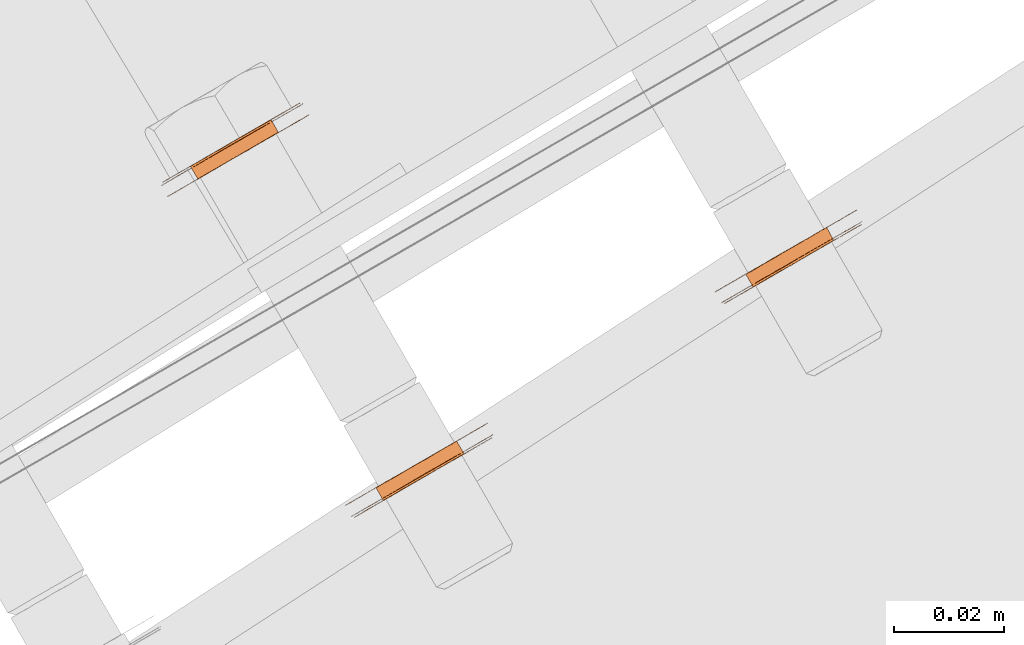
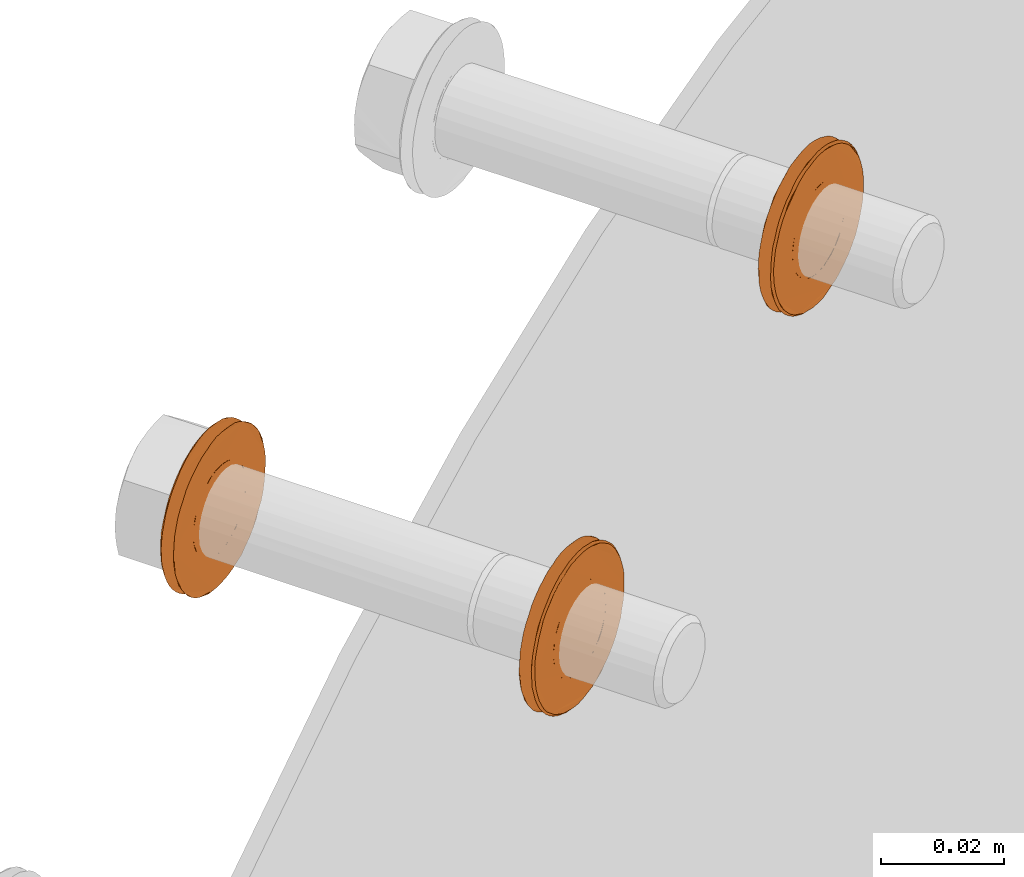
# One storey, part 108 of 126: 3 proxies.
"""IFC2X3 building model written with IfcOpenShell, lengths in millimetres."""

from ifc_helpers import new_model, si_unit, origin, origin_with_axes, place, context, project, spatial, faceted_brep, material, element, save


model = new_model("IFC2X3")

# Units and contexts
context_of_model_1 = context(None, 3, precision=0.1, world=origin())
context_of_model_2 = context(None, 3, precision=0.1, world=origin())
ifc_project = project(units=[si_unit("LENGTHUNIT", "METRE", prefix="MILLI"), si_unit("AREAUNIT", "SQUARE_METRE", prefix="CENTI"), si_unit("VOLUMEUNIT", "CUBIC_METRE", prefix="CENTI"), si_unit("MASSUNIT", "GRAM", prefix="KILO")], contexts=[context_of_model_1, context_of_model_2])

# Site, building, storey
site_placement = place(None, origin_with_axes())
site = spatial("IfcSite", under=ifc_project, at=site_placement, CompositionType="ELEMENT")
building_placement = place(site_placement, origin_with_axes())
building = spatial("IfcBuilding", under=site, at=building_placement, CompositionType="ELEMENT")
storey_placement = place(building_placement, origin_with_axes())
storey = spatial("IfcBuildingStorey", under=building, at=storey_placement, CompositionType="ELEMENT")

# Proxies
ifc_material = material(Name="STAHL")
proxy_1_placement = place(storey_placement, origin_with_axes())
element("IfcBuildingElementProxy", 1, at=proxy_1_placement, inside=storey, material=ifc_material, Name="profile", context=context_of_model_2, shape_type="Brep", body=[
    faceted_brep([(3844.0, 14806.0, 1266.7), (3842.7, 14808.3, 1266.7), (3841.6, 14807.7, 1266.9), (3843.0, 14805.4, 1266.9), (3845.1, 14806.6, 1266.8), (3843.7, 14808.9, 1266.8), (3846.1, 14807.2, 1267.0), (3844.8, 14809.5, 1267.0), (3840.5, 14804.0, 1282.5), (3839.2, 14806.3, 1282.5), (3840.1, 14806.8, 1283.1), (3841.5, 14804.5, 1283.1), (3847.1, 14807.8, 1267.4), (3845.8, 14810.1, 1267.4), (3839.7, 14803.5, 1281.8), (3838.3, 14805.8, 1281.8), (3838.9, 14803.0, 1281.0), (3837.6, 14805.4, 1281.0), (3838.3, 14802.6, 1280.1), (3836.9, 14805.0, 1280.1), (3837.7, 14802.3, 1279.0), (3836.4, 14804.7, 1279.0), (3837.3, 14802.1, 1277.9), (3836.0, 14804.4, 1277.9), (3837.1, 14801.9, 1276.7), (3835.7, 14804.3, 1276.7), (3836.9, 14801.9, 1275.5), (3835.6, 14804.2, 1275.5), (3837.0, 14801.9, 1274.3), (3835.6, 14804.2, 1274.3), (3837.2, 14802.0, 1273.1), (3835.8, 14804.4, 1273.1), (3837.5, 14802.2, 1272.0), (3836.2, 14804.5, 1272.0), (3838.0, 14802.5, 1270.9), (3836.6, 14804.8, 1270.9), (3838.6, 14802.8, 1269.9), (3837.2, 14805.2, 1269.9), (3839.3, 14803.2, 1269.0), (3837.9, 14805.6, 1269.0), (3840.1, 14803.7, 1268.2), (3838.8, 14806.0, 1268.2), (3841.0, 14804.2, 1267.6), (3839.7, 14806.6, 1267.6), (3842.0, 14804.8, 1267.2), (3840.6, 14807.1, 1267.2), (3831.1, 14799.0, 1275.6), (3831.2, 14799.0, 1277.2), (3831.5, 14799.2, 1278.7), (3831.9, 14799.4, 1280.2), (3832.4, 14799.7, 1281.7), (3833.0, 14800.1, 1283.1), (3833.8, 14800.5, 1284.4), (3834.7, 14801.0, 1285.6), (3835.7, 14801.6, 1286.6), (3836.7, 14802.2, 1287.6), (3837.9, 14802.9, 1288.4), (3839.1, 14803.6, 1289.1), (3840.4, 14804.3, 1289.6), (3841.7, 14805.1, 1290.0), (3843.1, 14805.9, 1290.2), (3844.4, 14806.7, 1290.2), (3845.8, 14807.5, 1290.1), (3847.1, 14808.2, 1289.8), (3848.4, 14809.0, 1289.4), (3849.7, 14809.7, 1288.8), (3850.9, 14810.4, 1288.0), (3852.0, 14811.0, 1287.1), (3853.0, 14811.6, 1286.1), (3854.0, 14812.2, 1285.0), (3854.8, 14812.7, 1283.7), (3855.5, 14813.1, 1282.4), (3856.1, 14813.4, 1281.0), (3856.6, 14813.7, 1279.5), (3856.9, 14813.9, 1278.0), (3857.1, 14814.0, 1276.4), (3857.1, 14814.0, 1274.8), (3857.0, 14813.9, 1273.3), (3856.7, 14813.8, 1271.7), (3856.4, 14813.5, 1270.2), (3855.8, 14813.2, 1268.8), (3855.2, 14812.9, 1267.4), (3854.4, 14812.4, 1266.1), (3853.5, 14811.9, 1264.9), (3852.5, 14811.3, 1263.8), (3851.5, 14810.7, 1262.9), (3850.3, 14810.1, 1262.0), (3849.1, 14809.3, 1261.4), (3847.8, 14808.6, 1260.8), (3846.5, 14807.8, 1260.5), (3845.1, 14807.1, 1260.3), (3843.8, 14806.3, 1260.2), (3842.4, 14805.5, 1260.4), (3841.1, 14804.7, 1260.6), (3839.8, 14804.0, 1261.1), (3838.5, 14803.2, 1261.7), (3837.3, 14802.6, 1262.4), (3836.2, 14801.9, 1263.3), (3835.0, 14803.9, 1263.3), (3836.2, 14804.6, 1262.4), (3837.4, 14805.2, 1261.7), (3838.6, 14806.0, 1261.1), (3839.9, 14806.7, 1260.6), (3841.3, 14807.5, 1260.4), (3842.6, 14808.3, 1260.2), (3844.0, 14809.1, 1260.3), (3845.3, 14809.8, 1260.5), (3846.6, 14810.6, 1260.8), (3847.9, 14811.3, 1261.4), (3849.2, 14812.0, 1262.0), (3850.3, 14812.7, 1262.9), (3851.4, 14813.3, 1263.8), (3852.4, 14813.9, 1264.9), (3853.3, 14814.4, 1266.1), (3854.0, 14814.9, 1267.4), (3854.7, 14815.2, 1268.8), (3855.2, 14815.5, 1270.2), (3855.6, 14815.8, 1271.7), (3855.8, 14815.9, 1273.3), (3855.9, 14816.0, 1274.8), (3855.9, 14815.9, 1276.4), (3855.7, 14815.8, 1278.0), (3855.4, 14815.7, 1279.5), (3855.0, 14815.4, 1281.0), (3854.4, 14815.1, 1282.4), (3853.7, 14814.7, 1283.7), (3852.8, 14814.2, 1285.0), (3851.9, 14813.6, 1286.1), (3850.9, 14813.0, 1287.1), (3849.7, 14812.4, 1288.0), (3848.5, 14811.7, 1288.8), (3847.3, 14811.0, 1289.4), (3846.0, 14810.2, 1289.8), (3844.7, 14809.4, 1290.1), (3843.3, 14808.7, 1290.2), (3841.9, 14807.9, 1290.2), (3840.6, 14807.1, 1290.0), (3839.3, 14806.3, 1289.6), (3838.0, 14805.6, 1289.1), (3836.8, 14804.9, 1288.4), (3835.6, 14804.2, 1287.6), (3834.5, 14803.6, 1286.6), (3833.5, 14803.0, 1285.6), (3832.7, 14802.5, 1284.4), (3831.9, 14802.1, 1283.1), (3831.2, 14801.7, 1281.7), (3830.7, 14801.4, 1280.2), (3830.3, 14801.2, 1278.7), (3830.1, 14801.0, 1277.2), (3830.0, 14801.0, 1275.6), (3830.0, 14801.0, 1274.0), (3830.2, 14801.1, 1272.5), (3830.5, 14801.3, 1271.0), (3831.0, 14801.5, 1269.5), (3831.5, 14801.9, 1268.1), (3832.3, 14802.3, 1266.7), (3833.1, 14802.8, 1265.5), (3834.0, 14803.3, 1264.3), (3835.2, 14801.3, 1264.3), (3834.2, 14800.8, 1265.5), (3833.4, 14800.3, 1266.7), (3832.7, 14799.9, 1268.1), (3832.1, 14799.5, 1269.5), (3831.7, 14799.3, 1271.0), (3831.3, 14799.1, 1272.5), (3831.2, 14799.0, 1274.0), (3831.7, 14798.8, 1275.0), (3831.7, 14798.9, 1276.6), (3831.9, 14799.0, 1278.2), (3832.3, 14799.2, 1279.7), (3832.8, 14799.5, 1281.2), (3833.4, 14799.8, 1282.6), (3834.1, 14800.3, 1283.9), (3835.0, 14800.8, 1285.1), (3836.0, 14801.3, 1286.2), (3837.1, 14802.0, 1287.2), (3838.2, 14802.6, 1288.0), (3839.5, 14803.3, 1288.7), (3840.8, 14804.1, 1289.2), (3842.1, 14804.9, 1289.6), (3843.5, 14805.6, 1289.8), (3844.8, 14806.4, 1289.8), (3846.2, 14807.2, 1289.7), (3847.5, 14808.0, 1289.3), (3848.8, 14808.7, 1288.9), (3850.1, 14809.5, 1288.2), (3851.3, 14810.1, 1287.4), (3852.4, 14810.8, 1286.5), (3853.4, 14811.4, 1285.4), (3854.3, 14811.9, 1284.2), (3855.1, 14812.3, 1282.9), (3855.7, 14812.7, 1281.5), (3856.2, 14813.0, 1280.1), (3856.6, 14813.2, 1278.6), (3856.9, 14813.4, 1277.0), (3856.9, 14813.4, 1275.4), (3856.9, 14813.4, 1273.8), (3856.7, 14813.3, 1272.3), (3856.3, 14813.1, 1270.8), (3855.9, 14812.8, 1269.3), (3855.2, 14812.4, 1267.9), (3854.5, 14812.0, 1266.5), (3853.6, 14811.5, 1265.3), (3852.6, 14810.9, 1264.2), (3851.5, 14810.3, 1263.3), (3850.4, 14809.6, 1262.4), (3849.1, 14808.9, 1261.7), (3847.9, 14808.2, 1261.2), (3846.5, 14807.4, 1260.9), (3845.2, 14806.6, 1260.7), (3843.8, 14805.8, 1260.6), (3842.4, 14805.0, 1260.8), (3841.1, 14804.3, 1261.1), (3839.8, 14803.5, 1261.6), (3838.5, 14802.8, 1262.2), (3837.4, 14802.1, 1263.0), (3836.3, 14801.5, 1264.0), (3835.2, 14800.9, 1265.0), (3834.3, 14800.4, 1266.2), (3833.6, 14799.9, 1267.5), (3832.9, 14799.5, 1268.9), (3832.4, 14799.2, 1270.4), (3832.0, 14799.0, 1271.9), (3831.8, 14798.9, 1273.5), (3850.9, 14809.9, 1271.4), (3850.4, 14809.6, 1270.4), (3849.7, 14809.2, 1269.4), (3848.9, 14808.8, 1268.6), (3848.1, 14808.3, 1267.9), (3842.5, 14805.1, 1283.5), (3843.5, 14805.7, 1283.7), (3844.6, 14806.3, 1283.7), (3845.6, 14806.9, 1283.6), (3846.6, 14807.5, 1283.3), (3847.6, 14808.0, 1282.8), (3848.5, 14808.6, 1282.2), (3849.3, 14809.0, 1281.4), (3850.0, 14809.4, 1280.6), (3850.6, 14809.8, 1279.6), (3851.1, 14810.1, 1278.5), (3851.4, 14810.2, 1277.3), (3851.6, 14810.4, 1276.1), (3851.7, 14810.4, 1274.9), (3851.6, 14810.3, 1273.7), (3851.3, 14810.2, 1272.5), (3843.2, 14808.6, 1283.7), (3844.3, 14809.2, 1283.6), (3842.2, 14808.0, 1283.7), (3841.1, 14807.4, 1283.5), (3846.7, 14810.6, 1267.9), (3847.6, 14811.1, 1268.6), (3848.3, 14811.6, 1269.4), (3849.0, 14812.0, 1270.4), (3849.5, 14812.3, 1271.4), (3849.9, 14812.5, 1272.5), (3850.2, 14812.7, 1273.7), (3850.3, 14812.7, 1274.9), (3850.3, 14812.7, 1276.1), (3850.1, 14812.6, 1277.3), (3849.8, 14812.4, 1278.5), (3849.3, 14812.1, 1279.6), (3848.7, 14811.8, 1280.6), (3848.0, 14811.4, 1281.4), (3847.2, 14810.9, 1282.2), (3846.3, 14810.4, 1282.8), (3845.3, 14809.8, 1283.3)], [[[0, 1, 2, 3]], [[4, 5, 1, 0]], [[6, 7, 5, 4]], [[8, 9, 10, 11]], [[12, 13, 7, 6]], [[14, 15, 9, 8]], [[16, 17, 15, 14]], [[18, 19, 17, 16]], [[20, 21, 19, 18]], [[22, 23, 21, 20]], [[24, 25, 23, 22]], [[26, 27, 25, 24]], [[28, 29, 27, 26]], [[30, 31, 29, 28]], [[32, 33, 31, 30]], [[34, 35, 33, 32]], [[36, 37, 35, 34]], [[38, 39, 37, 36]], [[40, 41, 39, 38]], [[42, 43, 41, 40]], [[44, 45, 43, 42]], [[3, 2, 45, 44]], [[46, 47, 48, 49, 50, 51, 52, 53, 54, 55, 56, 57, 58, 59, 60, 61, 62, 63, 64, 65, 66, 67, 68, 69, 70, 71, 72, 73, 74, 75, 76, 77, 78, 79, 80, 81, 82, 83, 84, 85, 86, 87, 88, 89, 90, 91, 92, 93, 94, 95, 96, 97, 98, 99, 100, 101, 102, 103, 104, 105, 106, 107, 108, 109, 110, 111, 112, 113, 114, 115, 116, 117, 118, 119, 120, 121, 122, 123, 124, 125, 126, 127, 128, 129, 130, 131, 132, 133, 134, 135, 136, 137, 138, 139, 140, 141, 142, 143, 144, 145, 146, 147, 148, 149, 150, 151, 152, 153, 154, 155, 156, 157, 98, 97, 158, 159, 160, 161, 162, 163, 164, 165]], [[166, 167, 168, 169, 170, 171, 172, 173, 174, 175, 176, 177, 178, 179, 180, 181, 182, 183, 184, 185, 186, 187, 188, 189, 190, 191, 192, 193, 194, 195, 196, 197, 198, 79, 78, 77, 76, 75, 74, 73, 72, 71, 70, 69, 68, 67, 66, 65, 64, 63, 62, 61, 60, 59, 58, 57, 56, 55, 54, 53, 52, 51, 50, 49, 48, 47, 46, 165, 164, 163, 162, 161, 160, 159, 158, 97, 96, 95, 94, 93, 92, 91, 90, 89, 88, 87, 86, 85, 84, 83, 82, 81, 80, 79, 198, 199, 200, 201, 202, 203, 204, 205, 206, 207, 208, 209, 210, 211, 212, 213, 214, 215, 216, 217, 218, 219, 220, 221, 222, 223]], [[166, 223, 222, 221, 220, 219, 218, 217, 216, 215, 214, 213, 212, 211, 210, 209, 208, 207, 206, 205, 204, 203, 202, 201, 200, 199, 224, 225, 226, 227, 228, 12, 6, 4, 0, 3, 44, 42, 40, 38, 36, 34, 32, 30, 28, 26, 24, 22, 20, 18, 16, 14, 8, 11, 229, 230, 231, 232, 233, 234, 235, 236, 237, 238, 239, 240, 241, 242, 243, 244, 224, 199, 198, 197, 196, 195, 194, 193, 192, 191, 190, 189, 188, 187, 186, 185, 184, 183, 182, 181, 180, 179, 178, 177, 176, 175, 174, 173, 172, 171, 170, 169, 168, 167]], [[231, 245, 246, 232]], [[230, 247, 245, 231]], [[229, 248, 247, 230]], [[228, 249, 13, 12]], [[11, 10, 248, 229]], [[227, 250, 249, 228]], [[226, 251, 250, 227]], [[225, 252, 251, 226]], [[224, 253, 252, 225]], [[244, 254, 253, 224]], [[243, 255, 254, 244]], [[242, 256, 255, 243]], [[241, 257, 256, 242]], [[240, 258, 257, 241]], [[239, 259, 258, 240]], [[238, 260, 259, 239]], [[237, 261, 260, 238]], [[236, 262, 261, 237]], [[235, 263, 262, 236]], [[234, 264, 263, 235]], [[233, 265, 264, 234]], [[232, 246, 265, 233]], [[149, 148, 147, 146, 145, 144, 143, 142, 141, 140, 139, 138, 137, 136, 135, 134, 133, 132, 131, 130, 129, 128, 127, 126, 125, 124, 123, 122, 121, 120, 119, 118, 117, 116, 254, 255, 256, 257, 258, 259, 260, 261, 262, 263, 264, 265, 246, 245, 247, 248, 10, 9, 15, 17, 19, 21, 23, 25, 27, 29, 31, 33, 35, 37, 39, 41, 43, 45, 2, 1, 5, 7, 13, 249, 250, 251, 252, 253, 254, 116, 115, 114, 113, 112, 111, 110, 109, 108, 107, 106, 105, 104, 103, 102, 101, 100, 99, 98, 157, 156, 155, 154, 153, 152, 151, 150]]]),
])
proxy_2_placement = place(storey_placement, origin_with_axes())
element("IfcBuildingElementProxy", 2, at=proxy_2_placement, inside=storey, material=ifc_material, Name="profile", context=context_of_model_2, shape_type="Brep", body=[
    faceted_brep([(3814.5, 14870.2, 1269.4), (3815.8, 14867.9, 1269.4), (3816.5, 14868.3, 1270.4), (3815.2, 14870.6, 1270.4), (3813.7, 14869.8, 1268.6), (3815.1, 14867.4, 1268.6), (3812.9, 14869.3, 1267.9), (3814.2, 14866.9, 1267.9), (3807.3, 14866.0, 1283.5), (3808.6, 14863.7, 1283.5), (3807.6, 14863.1, 1283.1), (3806.3, 14865.5, 1283.1), (3811.9, 14868.7, 1267.4), (3813.3, 14866.4, 1267.4), (3808.3, 14866.6, 1283.7), (3809.7, 14864.3, 1283.7), (3809.4, 14867.3, 1283.7), (3810.7, 14864.9, 1283.7), (3810.4, 14867.9, 1283.6), (3811.8, 14865.5, 1283.6), (3811.4, 14868.4, 1283.3), (3812.8, 14866.1, 1283.3), (3812.4, 14869.0, 1282.8), (3813.8, 14866.7, 1282.8), (3813.3, 14869.5, 1282.2), (3814.7, 14867.2, 1282.2), (3814.1, 14870.0, 1281.4), (3815.5, 14867.7, 1281.4), (3814.8, 14870.4, 1280.6), (3816.2, 14868.1, 1280.6), (3815.4, 14870.8, 1279.6), (3816.8, 14868.4, 1279.6), (3815.9, 14871.0, 1278.5), (3817.3, 14868.7, 1278.5), (3816.2, 14871.2, 1277.3), (3817.6, 14868.9, 1277.3), (3816.4, 14871.3, 1276.1), (3817.8, 14869.0, 1276.1), (3816.5, 14871.3, 1274.9), (3817.8, 14869.0, 1274.9), (3816.4, 14871.3, 1273.7), (3817.7, 14868.9, 1273.7), (3816.1, 14871.1, 1272.5), (3817.4, 14868.8, 1272.5), (3815.7, 14870.9, 1271.4), (3817.0, 14868.6, 1271.4), (3797.5, 14857.3, 1275.6), (3797.6, 14857.3, 1277.2), (3797.8, 14857.5, 1278.7), (3798.2, 14857.7, 1280.2), (3798.7, 14858.0, 1281.7), (3799.4, 14858.4, 1283.1), (3800.2, 14858.8, 1284.4), (3801.0, 14859.3, 1285.6), (3802.0, 14859.9, 1286.6), (3803.1, 14860.5, 1287.6), (3804.3, 14861.2, 1288.4), (3805.5, 14861.9, 1289.1), (3806.8, 14862.6, 1289.6), (3808.1, 14863.4, 1290.0), (3809.4, 14864.2, 1290.2), (3810.8, 14865.0, 1290.2), (3812.2, 14865.7, 1290.1), (3813.5, 14866.5, 1289.8), (3814.8, 14867.3, 1289.4), (3816.0, 14868.0, 1288.8), (3817.2, 14868.7, 1288.0), (3818.4, 14869.3, 1287.1), (3819.4, 14869.9, 1286.1), (3820.3, 14870.5, 1285.0), (3821.2, 14870.9, 1283.7), (3821.9, 14871.4, 1282.4), (3822.5, 14871.7, 1281.0), (3822.9, 14872.0, 1279.5), (3823.2, 14872.1, 1278.0), (3823.4, 14872.2, 1276.4), (3823.4, 14872.3, 1274.8), (3823.3, 14872.2, 1273.3), (3823.1, 14872.1, 1271.7), (3821.9, 14874.0, 1271.7), (3822.2, 14874.2, 1273.3), (3822.3, 14874.3, 1274.8), (3822.3, 14874.2, 1276.4), (3822.1, 14874.1, 1278.0), (3821.8, 14873.9, 1279.5), (3821.3, 14873.7, 1281.0), (3820.7, 14873.3, 1282.4), (3820.0, 14872.9, 1283.7), (3819.2, 14872.5, 1285.0), (3818.2, 14871.9, 1286.1), (3817.2, 14871.3, 1287.1), (3816.1, 14870.7, 1288.0), (3814.9, 14870.0, 1288.8), (3813.6, 14869.3, 1289.4), (3812.3, 14868.5, 1289.8), (3811.0, 14867.7, 1290.1), (3809.6, 14867.0, 1290.2), (3808.3, 14866.2, 1290.2), (3806.9, 14865.4, 1290.0), (3805.6, 14864.6, 1289.6), (3804.3, 14863.9, 1289.1), (3803.1, 14863.2, 1288.4), (3801.9, 14862.5, 1287.6), (3800.9, 14861.9, 1286.6), (3799.9, 14861.3, 1285.6), (3799.0, 14860.8, 1284.4), (3798.2, 14860.4, 1283.1), (3797.6, 14860.0, 1281.7), (3797.1, 14859.7, 1280.2), (3796.7, 14859.5, 1278.7), (3796.4, 14859.3, 1277.2), (3796.3, 14859.3, 1275.6), (3796.4, 14859.3, 1274.0), (3796.5, 14859.4, 1272.5), (3796.9, 14859.6, 1271.0), (3797.3, 14859.8, 1269.5), (3797.9, 14860.2, 1268.1), (3798.6, 14860.6, 1266.7), (3799.4, 14861.1, 1265.5), (3800.4, 14861.6, 1264.3), (3801.4, 14862.2, 1263.3), (3802.5, 14862.8, 1262.4), (3803.7, 14863.5, 1261.7), (3805.0, 14864.3, 1261.1), (3806.3, 14865.0, 1260.6), (3807.6, 14865.8, 1260.4), (3809.0, 14866.6, 1260.2), (3810.3, 14867.3, 1260.3), (3811.7, 14868.1, 1260.5), (3813.0, 14868.9, 1260.8), (3814.3, 14869.6, 1261.4), (3815.5, 14870.3, 1262.0), (3816.7, 14871.0, 1262.9), (3817.7, 14871.6, 1263.8), (3818.7, 14872.2, 1264.9), (3819.6, 14872.7, 1266.1), (3820.4, 14873.1, 1267.4), (3821.0, 14873.5, 1268.8), (3821.6, 14873.8, 1270.2), (3822.7, 14871.8, 1270.2), (3822.2, 14871.5, 1268.8), (3821.5, 14871.2, 1267.4), (3820.8, 14870.7, 1266.1), (3819.9, 14870.2, 1264.9), (3818.9, 14869.6, 1263.8), (3817.8, 14869.0, 1262.9), (3816.7, 14868.3, 1262.0), (3815.4, 14867.6, 1261.4), (3814.1, 14866.9, 1260.8), (3812.8, 14866.1, 1260.5), (3811.5, 14865.4, 1260.3), (3810.1, 14864.6, 1260.2), (3808.8, 14863.8, 1260.4), (3807.4, 14863.0, 1260.6), (3806.1, 14862.3, 1261.1), (3804.9, 14861.5, 1261.7), (3803.7, 14860.8, 1262.4), (3802.5, 14860.2, 1263.3), (3801.5, 14859.6, 1264.3), (3800.6, 14859.1, 1265.5), (3799.8, 14858.6, 1266.7), (3799.0, 14858.2, 1268.1), (3798.5, 14857.8, 1269.5), (3798.0, 14857.6, 1271.0), (3797.7, 14857.4, 1272.5), (3797.5, 14857.3, 1274.0), (3803.3, 14863.8, 1262.2), (3804.6, 14864.5, 1261.6), (3805.9, 14865.2, 1261.1), (3807.2, 14866.0, 1260.8), (3808.6, 14866.8, 1260.6), (3810.0, 14867.6, 1260.7), (3811.3, 14868.4, 1260.9), (3812.7, 14869.1, 1261.2), (3813.9, 14869.9, 1261.7), (3815.2, 14870.6, 1262.4), (3816.3, 14871.3, 1263.3), (3817.4, 14871.9, 1264.2), (3818.4, 14872.5, 1265.3), (3819.3, 14873.0, 1266.5), (3820.0, 14873.4, 1267.9), (3820.7, 14873.8, 1269.3), (3821.1, 14874.0, 1270.8), (3821.5, 14874.3, 1272.3), (3821.7, 14874.4, 1273.8), (3821.7, 14874.4, 1275.4), (3821.7, 14874.3, 1277.0), (3821.4, 14874.2, 1278.6), (3821.0, 14874.0, 1280.1), (3820.5, 14873.7, 1281.5), (3819.9, 14873.3, 1282.9), (3819.1, 14872.9, 1284.2), (3818.2, 14872.3, 1285.4), (3817.2, 14871.8, 1286.5), (3816.1, 14871.1, 1287.4), (3814.9, 14870.4, 1288.2), (3813.6, 14869.7, 1288.9), (3812.3, 14869.0, 1289.3), (3811.0, 14868.2, 1289.7), (3809.6, 14867.4, 1289.8), (3808.3, 14866.6, 1289.8), (3806.9, 14865.8, 1289.6), (3805.6, 14865.1, 1289.2), (3804.3, 14864.3, 1288.7), (3803.0, 14863.6, 1288.0), (3801.9, 14862.9, 1287.2), (3800.8, 14862.3, 1286.2), (3799.8, 14861.7, 1285.1), (3798.9, 14861.2, 1283.9), (3798.2, 14860.8, 1282.6), (3797.6, 14860.4, 1281.2), (3797.1, 14860.2, 1279.7), (3796.7, 14860.0, 1278.2), (3796.5, 14859.8, 1276.6), (3796.5, 14859.8, 1275.0), (3796.6, 14859.9, 1273.5), (3796.8, 14860.0, 1271.9), (3797.2, 14860.2, 1270.4), (3797.7, 14860.5, 1268.9), (3798.4, 14860.9, 1267.5), (3799.1, 14861.3, 1266.2), (3800.0, 14861.9, 1265.0), (3801.1, 14862.5, 1264.0), (3802.2, 14863.1, 1263.0), (3806.8, 14865.8, 1267.2), (3807.8, 14866.3, 1266.9), (3808.8, 14866.9, 1266.7), (3809.9, 14867.6, 1266.8), (3810.9, 14868.2, 1267.0), (3805.3, 14864.9, 1282.5), (3804.5, 14864.4, 1281.8), (3803.7, 14864.0, 1281.0), (3803.1, 14863.6, 1280.1), (3802.5, 14863.3, 1279.0), (3802.1, 14863.1, 1277.9), (3801.9, 14862.9, 1276.7), (3801.7, 14862.9, 1275.5), (3801.8, 14862.9, 1274.3), (3802.0, 14863.0, 1273.1), (3802.3, 14863.2, 1272.0), (3802.8, 14863.4, 1270.9), (3803.4, 14863.8, 1269.9), (3804.1, 14864.2, 1269.0), (3804.9, 14864.7, 1268.2), (3805.8, 14865.2, 1267.6), (3805.1, 14861.7, 1281.0), (3804.4, 14861.3, 1280.1), (3805.8, 14862.1, 1281.8), (3806.7, 14862.6, 1282.5), (3812.3, 14865.8, 1267.0), (3811.2, 14865.2, 1266.8), (3810.2, 14864.6, 1266.7), (3809.1, 14864.0, 1266.9), (3808.1, 14863.4, 1267.2), (3807.2, 14862.9, 1267.6), (3806.3, 14862.3, 1268.2), (3805.4, 14861.9, 1269.0), (3804.7, 14861.5, 1269.9), (3804.1, 14861.1, 1270.9), (3803.7, 14860.8, 1272.0), (3803.3, 14860.6, 1273.1), (3803.1, 14860.5, 1274.3), (3803.1, 14860.5, 1275.5), (3803.2, 14860.6, 1276.7), (3803.5, 14860.7, 1277.9), (3803.9, 14861.0, 1279.0)], [[[0, 1, 2, 3]], [[4, 5, 1, 0]], [[6, 7, 5, 4]], [[8, 9, 10, 11]], [[12, 13, 7, 6]], [[14, 15, 9, 8]], [[16, 17, 15, 14]], [[18, 19, 17, 16]], [[20, 21, 19, 18]], [[22, 23, 21, 20]], [[24, 25, 23, 22]], [[26, 27, 25, 24]], [[28, 29, 27, 26]], [[30, 31, 29, 28]], [[32, 33, 31, 30]], [[34, 35, 33, 32]], [[36, 37, 35, 34]], [[38, 39, 37, 36]], [[40, 41, 39, 38]], [[42, 43, 41, 40]], [[44, 45, 43, 42]], [[3, 2, 45, 44]], [[46, 47, 48, 49, 50, 51, 52, 53, 54, 55, 56, 57, 58, 59, 60, 61, 62, 63, 64, 65, 66, 67, 68, 69, 70, 71, 72, 73, 74, 75, 76, 77, 78, 79, 80, 81, 82, 83, 84, 85, 86, 87, 88, 89, 90, 91, 92, 93, 94, 95, 96, 97, 98, 99, 100, 101, 102, 103, 104, 105, 106, 107, 108, 109, 110, 111, 112, 113, 114, 115, 116, 117, 118, 119, 120, 121, 122, 123, 124, 125, 126, 127, 128, 129, 130, 131, 132, 133, 134, 135, 136, 137, 138, 79, 78, 139, 140, 141, 142, 143, 144, 145, 146, 147, 148, 149, 150, 151, 152, 153, 154, 155, 156, 157, 158, 159, 160, 161, 162, 163, 164, 165]], [[111, 110, 109, 108, 107, 106, 105, 104, 103, 102, 101, 100, 99, 98, 97, 96, 95, 94, 93, 92, 91, 90, 89, 88, 87, 86, 85, 84, 83, 82, 81, 80, 79, 138, 137, 136, 135, 134, 133, 132, 131, 130, 129, 128, 127, 126, 125, 124, 123, 122, 166, 167, 168, 169, 170, 171, 172, 173, 174, 175, 176, 177, 178, 179, 180, 181, 182, 183, 184, 185, 186, 187, 188, 189, 190, 191, 192, 193, 194, 195, 196, 197, 198, 199, 200, 201, 202, 203, 204, 205, 206, 207, 208, 209, 210, 211, 212, 213, 214, 215, 216, 217, 218, 219, 220, 221, 222, 223, 166, 122, 121, 120, 119, 118, 117, 116, 115, 114, 113, 112]], [[214, 213, 212, 211, 210, 209, 208, 207, 206, 205, 204, 203, 202, 201, 200, 199, 198, 197, 196, 195, 194, 193, 192, 191, 190, 189, 188, 187, 186, 185, 184, 183, 182, 181, 180, 179, 178, 177, 176, 175, 174, 173, 172, 171, 170, 169, 168, 167, 224, 225, 226, 227, 228, 12, 6, 4, 0, 3, 44, 42, 40, 38, 36, 34, 32, 30, 28, 26, 24, 22, 20, 18, 16, 14, 8, 11, 229, 230, 231, 232, 233, 234, 235, 236, 237, 238, 239, 240, 241, 242, 243, 244, 224, 167, 166, 223, 222, 221, 220, 219, 218, 217, 216, 215]], [[231, 245, 246, 232]], [[230, 247, 245, 231]], [[229, 248, 247, 230]], [[228, 249, 13, 12]], [[11, 10, 248, 229]], [[227, 250, 249, 228]], [[226, 251, 250, 227]], [[225, 252, 251, 226]], [[224, 253, 252, 225]], [[244, 254, 253, 224]], [[243, 255, 254, 244]], [[242, 256, 255, 243]], [[241, 257, 256, 242]], [[240, 258, 257, 241]], [[239, 259, 258, 240]], [[238, 260, 259, 239]], [[237, 261, 260, 238]], [[236, 262, 261, 237]], [[235, 263, 262, 236]], [[234, 264, 263, 235]], [[233, 265, 264, 234]], [[232, 246, 265, 233]], [[46, 165, 164, 163, 162, 161, 160, 159, 158, 157, 156, 155, 154, 254, 255, 256, 257, 258, 259, 260, 261, 262, 263, 264, 265, 246, 245, 247, 248, 10, 9, 15, 17, 19, 21, 23, 25, 27, 29, 31, 33, 35, 37, 39, 41, 43, 45, 2, 1, 5, 7, 13, 249, 250, 251, 252, 253, 254, 154, 153, 152, 151, 150, 149, 148, 147, 146, 145, 144, 143, 142, 141, 140, 139, 78, 77, 76, 75, 74, 73, 72, 71, 70, 69, 68, 67, 66, 65, 64, 63, 62, 61, 60, 59, 58, 57, 56, 55, 54, 53, 52, 51, 50, 49, 48, 47]]]),
])
proxy_3_placement = place(storey_placement, origin_with_axes())
element("IfcBuildingElementProxy", 3, at=proxy_3_placement, inside=storey, material=ifc_material, Name="profile", context=context_of_model_2, shape_type="Brep", body=[
    faceted_brep([(3911.1, 14844.7, 1299.0), (3909.7, 14847.0, 1299.0), (3908.7, 14846.4, 1299.2), (3910.1, 14844.1, 1299.2), (3912.1, 14845.3, 1299.0), (3910.8, 14847.6, 1299.0), (3910.3, 14844.2, 1315.8), (3909.3, 14843.7, 1315.5), (3908.0, 14846.0, 1315.5), (3909.0, 14846.6, 1315.8), (3913.2, 14845.9, 1299.1), (3911.8, 14848.2, 1299.1), (3908.3, 14843.1, 1315.0), (3907.0, 14845.4, 1315.0), (3907.4, 14842.6, 1314.4), (3906.1, 14844.9, 1314.4), (3906.6, 14842.1, 1313.6), (3905.3, 14844.5, 1313.6), (3905.9, 14841.7, 1312.7), (3904.6, 14844.1, 1312.7), (3905.4, 14841.4, 1311.7), (3904.0, 14843.7, 1311.7), (3904.9, 14841.1, 1310.6), (3903.6, 14843.5, 1310.6), (3904.6, 14840.9, 1309.4), (3903.2, 14843.3, 1309.4), (3904.4, 14840.8, 1308.2), (3903.1, 14843.2, 1308.2), (3904.4, 14840.8, 1307.0), (3903.0, 14843.2, 1307.0), (3904.5, 14840.9, 1305.8), (3903.2, 14843.2, 1305.8), (3904.8, 14841.1, 1304.7), (3903.5, 14843.4, 1304.7), (3905.2, 14841.3, 1303.5), (3903.9, 14843.6, 1303.5), (3905.8, 14841.6, 1302.5), (3904.4, 14844.0, 1302.5), (3906.5, 14842.0, 1301.6), (3905.1, 14844.4, 1301.6), (3907.2, 14842.5, 1300.8), (3905.9, 14844.8, 1300.8), (3908.1, 14843.0, 1300.1), (3906.8, 14845.3, 1300.1), (3909.1, 14843.5, 1299.6), (3907.7, 14845.9, 1299.6), (3898.6, 14837.9, 1307.7), (3898.7, 14838.0, 1309.2), (3898.9, 14838.1, 1310.8), (3899.2, 14838.3, 1312.3), (3899.8, 14838.6, 1313.8), (3900.4, 14839.0, 1315.2), (3901.1, 14839.4, 1316.5), (3902.0, 14839.9, 1317.7), (3903.0, 14840.5, 1318.8), (3904.1, 14841.1, 1319.7), (3905.2, 14841.8, 1320.6), (3906.4, 14842.5, 1321.3), (3907.7, 14843.2, 1321.8), (3909.0, 14844.0, 1322.2), (3910.4, 14844.7, 1322.4), (3911.7, 14845.5, 1322.5), (3913.1, 14846.3, 1322.4), (3914.4, 14847.1, 1322.1), (3915.7, 14847.8, 1321.7), (3917.0, 14848.6, 1321.1), (3918.2, 14849.3, 1320.4), (3919.3, 14849.9, 1319.5), (3920.4, 14850.5, 1318.5), (3921.3, 14851.1, 1317.4), (3922.2, 14851.5, 1316.1), (3922.9, 14852.0, 1314.8), (3923.5, 14852.3, 1313.4), (3924.0, 14852.6, 1311.9), (3924.3, 14852.8, 1310.4), (3924.5, 14852.9, 1308.9), (3924.5, 14852.9, 1307.3), (3924.5, 14852.9, 1305.7), (3924.2, 14852.7, 1304.2), (3923.9, 14852.5, 1302.7), (3923.3, 14852.2, 1301.2), (3922.7, 14851.9, 1299.8), (3922.0, 14851.4, 1298.5), (3921.1, 14850.9, 1297.3), (3920.1, 14850.4, 1296.2), (3919.0, 14849.7, 1295.2), (3917.9, 14849.1, 1294.4), (3916.7, 14848.4, 1293.7), (3915.4, 14847.6, 1293.2), (3914.1, 14846.9, 1292.8), (3912.7, 14846.1, 1292.5), (3911.4, 14845.3, 1292.5), (3910.0, 14844.5, 1292.6), (3908.7, 14843.8, 1292.9), (3907.4, 14843.0, 1293.3), (3906.1, 14842.3, 1293.9), (3904.9, 14841.6, 1294.6), (3903.8, 14840.9, 1295.5), (3902.7, 14840.3, 1296.5), (3901.8, 14839.8, 1297.6), (3900.6, 14841.8, 1297.6), (3901.6, 14842.3, 1296.5), (3902.6, 14842.9, 1295.5), (3903.8, 14843.6, 1294.6), (3905.0, 14844.3, 1293.9), (3906.2, 14845.0, 1293.3), (3907.5, 14845.8, 1292.9), (3908.9, 14846.5, 1292.6), (3910.2, 14847.3, 1292.5), (3911.6, 14848.1, 1292.5), (3912.9, 14848.9, 1292.8), (3914.3, 14849.6, 1293.2), (3915.5, 14850.4, 1293.7), (3916.7, 14851.1, 1294.4), (3917.9, 14851.7, 1295.2), (3919.0, 14852.4, 1296.2), (3919.9, 14852.9, 1297.3), (3920.8, 14853.4, 1298.5), (3921.6, 14853.9, 1299.8), (3922.2, 14854.2, 1301.2), (3922.7, 14854.5, 1302.7), (3923.1, 14854.7, 1304.2), (3923.3, 14854.9, 1305.7), (3923.4, 14854.9, 1307.3), (3923.3, 14854.9, 1308.9), (3923.1, 14854.8, 1310.4), (3922.8, 14854.6, 1311.9), (3922.3, 14854.3, 1313.4), (3921.7, 14854.0, 1314.8), (3921.0, 14853.5, 1316.1), (3920.2, 14853.0, 1317.4), (3919.2, 14852.5, 1318.5), (3918.2, 14851.9, 1319.5), (3917.0, 14851.2, 1320.4), (3915.8, 14850.5, 1321.1), (3914.6, 14849.8, 1321.7), (3913.3, 14849.1, 1322.1), (3911.9, 14848.3, 1322.4), (3910.6, 14847.5, 1322.5), (3909.2, 14846.7, 1322.4), (3907.9, 14845.9, 1322.2), (3906.5, 14845.2, 1321.8), (3905.3, 14844.4, 1321.3), (3904.1, 14843.7, 1320.6), (3902.9, 14843.1, 1319.7), (3901.8, 14842.5, 1318.8), (3900.9, 14841.9, 1317.7), (3900.0, 14841.4, 1316.5), (3899.2, 14841.0, 1315.2), (3898.6, 14840.6, 1313.8), (3898.1, 14840.3, 1312.3), (3897.7, 14840.1, 1310.8), (3897.5, 14840.0, 1309.2), (3897.4, 14839.9, 1307.7), (3897.5, 14839.9, 1306.1), (3897.7, 14840.1, 1304.6), (3898.0, 14840.2, 1303.0), (3898.5, 14840.5, 1301.6), (3899.1, 14840.9, 1300.2), (3899.8, 14841.3, 1298.8), (3900.9, 14839.3, 1298.8), (3900.2, 14838.9, 1300.2), (3899.6, 14838.5, 1301.6), (3899.1, 14838.3, 1303.0), (3898.8, 14838.1, 1304.6), (3898.6, 14837.9, 1306.1), (3899.1, 14837.8, 1307.0), (3899.1, 14837.8, 1308.6), (3899.3, 14837.9, 1310.1), (3899.6, 14838.1, 1311.7), (3900.1, 14838.3, 1313.2), (3900.7, 14838.7, 1314.6), (3901.4, 14839.1, 1315.9), (3902.3, 14839.6, 1317.2), (3903.2, 14840.2, 1318.3), (3904.3, 14840.8, 1319.3), (3905.5, 14841.4, 1320.1), (3906.7, 14842.1, 1320.9), (3908.0, 14842.9, 1321.4), (3909.3, 14843.6, 1321.8), (3910.6, 14844.4, 1322.0), (3912.0, 14845.2, 1322.1), (3913.4, 14846.0, 1322.0), (3914.7, 14846.8, 1321.7), (3916.0, 14847.5, 1321.2), (3917.3, 14848.3, 1320.6), (3918.5, 14849.0, 1319.8), (3919.6, 14849.6, 1318.9), (3920.6, 14850.2, 1317.9), (3921.6, 14850.7, 1316.7), (3922.4, 14851.2, 1315.4), (3923.0, 14851.6, 1314.1), (3923.6, 14851.9, 1312.6), (3924.0, 14852.1, 1311.1), (3924.3, 14852.3, 1309.6), (3924.4, 14852.4, 1308.0), (3924.4, 14852.4, 1306.4), (3924.2, 14852.2, 1304.8), (3923.9, 14852.1, 1303.3), (3923.4, 14851.8, 1301.8), (3922.8, 14851.4, 1300.4), (3922.1, 14851.0, 1299.0), (3921.2, 14850.5, 1297.8), (3920.3, 14850.0, 1296.7), (3919.2, 14849.4, 1295.7), (3918.0, 14848.7, 1294.8), (3916.8, 14848.0, 1294.1), (3915.5, 14847.3, 1293.6), (3914.2, 14846.5, 1293.2), (3912.9, 14845.7, 1292.9), (3911.5, 14844.9, 1292.9), (3910.1, 14844.1, 1293.0), (3908.8, 14843.4, 1293.3), (3907.5, 14842.6, 1293.7), (3906.2, 14841.9, 1294.4), (3905.0, 14841.2, 1295.1), (3903.9, 14840.5, 1296.0), (3902.9, 14839.9, 1297.1), (3901.9, 14839.4, 1298.3), (3901.1, 14838.9, 1299.5), (3900.5, 14838.6, 1300.9), (3899.9, 14838.2, 1302.4), (3899.5, 14838.0, 1303.9), (3899.2, 14837.8, 1305.4), (3918.1, 14848.8, 1303.3), (3917.6, 14848.4, 1302.3), (3916.9, 14848.0, 1301.4), (3916.1, 14847.6, 1300.6), (3915.2, 14847.0, 1300.0), (3914.2, 14846.5, 1299.5), (3911.4, 14844.8, 1316.0), (3912.4, 14845.4, 1316.0), (3913.4, 14846.0, 1315.8), (3914.4, 14846.6, 1315.4), (3915.4, 14847.2, 1314.9), (3916.3, 14847.7, 1314.2), (3917.0, 14848.1, 1313.4), (3917.7, 14848.5, 1312.5), (3918.3, 14848.8, 1311.4), (3918.7, 14849.1, 1310.3), (3919.0, 14849.2, 1309.1), (3919.1, 14849.3, 1307.9), (3919.1, 14849.3, 1306.7), (3918.9, 14849.2, 1305.5), (3918.6, 14849.0, 1304.4), (3912.1, 14848.4, 1315.8), (3913.1, 14849.0, 1315.4), (3911.1, 14847.8, 1316.0), (3910.0, 14847.2, 1316.0), (3912.8, 14848.8, 1299.5), (3913.8, 14849.4, 1300.0), (3914.7, 14849.9, 1300.6), (3915.5, 14850.4, 1301.4), (3916.2, 14850.8, 1302.3), (3916.8, 14851.1, 1303.3), (3917.3, 14851.4, 1304.4), (3917.6, 14851.5, 1305.5), (3917.7, 14851.6, 1306.7), (3917.8, 14851.7, 1307.9), (3917.6, 14851.6, 1309.1), (3917.3, 14851.4, 1310.3), (3916.9, 14851.2, 1311.4), (3916.4, 14850.9, 1312.5), (3915.7, 14850.5, 1313.4), (3914.9, 14850.0, 1314.2), (3914.0, 14849.5, 1314.9)], [[[0, 1, 2, 3]], [[4, 5, 1, 0]], [[6, 7, 8, 9]], [[10, 11, 5, 4]], [[7, 12, 13, 8]], [[12, 14, 15, 13]], [[14, 16, 17, 15]], [[16, 18, 19, 17]], [[18, 20, 21, 19]], [[20, 22, 23, 21]], [[22, 24, 25, 23]], [[24, 26, 27, 25]], [[28, 29, 27, 26]], [[30, 31, 29, 28]], [[32, 33, 31, 30]], [[34, 35, 33, 32]], [[36, 37, 35, 34]], [[38, 39, 37, 36]], [[40, 41, 39, 38]], [[42, 43, 41, 40]], [[44, 45, 43, 42]], [[3, 2, 45, 44]], [[46, 47, 48, 49, 50, 51, 52, 53, 54, 55, 56, 57, 58, 59, 60, 61, 62, 63, 64, 65, 66, 67, 68, 69, 70, 71, 72, 73, 74, 75, 76, 77, 78, 79, 80, 81, 82, 83, 84, 85, 86, 87, 88, 89, 90, 91, 92, 93, 94, 95, 96, 97, 98, 99, 100, 101, 102, 103, 104, 105, 106, 107, 108, 109, 110, 111, 112, 113, 114, 115, 116, 117, 118, 119, 120, 121, 122, 123, 124, 125, 126, 127, 128, 129, 130, 131, 132, 133, 134, 135, 136, 137, 138, 139, 140, 141, 142, 143, 144, 145, 146, 147, 148, 149, 150, 151, 152, 153, 154, 155, 156, 157, 158, 159, 100, 99, 160, 161, 162, 163, 164, 165]], [[166, 167, 168, 169, 170, 171, 172, 173, 174, 175, 176, 177, 178, 179, 180, 181, 182, 183, 184, 185, 186, 187, 188, 189, 190, 191, 192, 193, 194, 195, 196, 197, 198, 199, 200, 81, 80, 79, 78, 77, 76, 75, 74, 73, 72, 71, 70, 69, 68, 67, 66, 65, 64, 63, 62, 61, 60, 59, 58, 57, 56, 55, 54, 53, 52, 51, 50, 49, 48, 47, 46, 165, 164, 163, 162, 161, 160, 99, 98, 97, 96, 95, 94, 93, 92, 91, 90, 89, 88, 87, 86, 85, 84, 83, 82, 81, 200, 201, 202, 203, 204, 205, 206, 207, 208, 209, 210, 211, 212, 213, 214, 215, 216, 217, 218, 219, 220, 221, 222, 223]], [[166, 223, 222, 221, 220, 219, 218, 217, 216, 215, 214, 213, 212, 211, 210, 209, 208, 207, 206, 205, 204, 203, 202, 201, 200, 199, 224, 225, 226, 227, 228, 229, 10, 4, 0, 3, 44, 42, 40, 38, 36, 34, 32, 30, 28, 26, 24, 22, 20, 18, 16, 14, 12, 7, 6, 230, 231, 232, 233, 234, 235, 236, 237, 238, 239, 240, 241, 242, 243, 244, 224, 199, 198, 197, 196, 195, 194, 193, 192, 191, 190, 189, 188, 187, 186, 185, 184, 183, 182, 181, 180, 179, 178, 177, 176, 175, 174, 173, 172, 171, 170, 169, 168, 167]], [[232, 245, 246, 233]], [[231, 247, 245, 232]], [[230, 248, 247, 231]], [[229, 249, 11, 10]], [[6, 9, 248, 230]], [[228, 250, 249, 229]], [[227, 251, 250, 228]], [[226, 252, 251, 227]], [[225, 253, 252, 226]], [[224, 254, 253, 225]], [[244, 255, 254, 224]], [[243, 256, 255, 244]], [[242, 257, 256, 243]], [[241, 258, 257, 242]], [[240, 259, 258, 241]], [[239, 260, 259, 240]], [[238, 261, 260, 239]], [[237, 262, 261, 238]], [[236, 263, 262, 237]], [[235, 264, 263, 236]], [[234, 265, 264, 235]], [[233, 246, 265, 234]], [[153, 152, 151, 150, 149, 148, 147, 146, 145, 144, 143, 142, 141, 140, 139, 138, 137, 136, 135, 134, 133, 132, 131, 130, 129, 128, 127, 126, 125, 124, 123, 122, 121, 120, 119, 118, 117, 116, 253, 254, 255, 256, 257, 258, 259, 260, 261, 262, 263, 264, 265, 246, 245, 247, 248, 9, 8, 13, 15, 17, 19, 21, 23, 25, 27, 29, 31, 33, 35, 37, 39, 41, 43, 45, 2, 1, 5, 11, 249, 250, 251, 252, 253, 116, 115, 114, 113, 112, 111, 110, 109, 108, 107, 106, 105, 104, 103, 102, 101, 100, 159, 158, 157, 156, 155, 154]]]),
])

save(model, "model.ifc")
